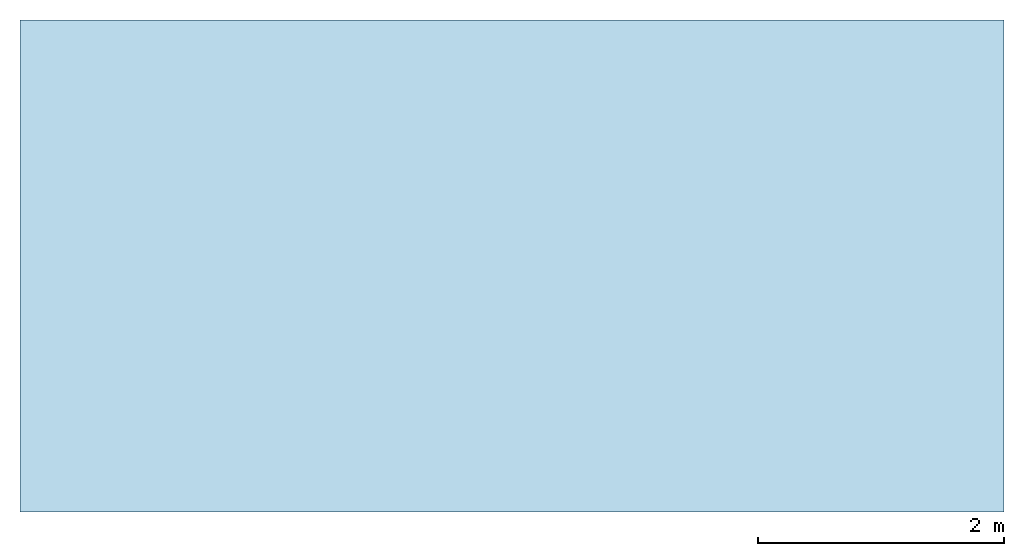
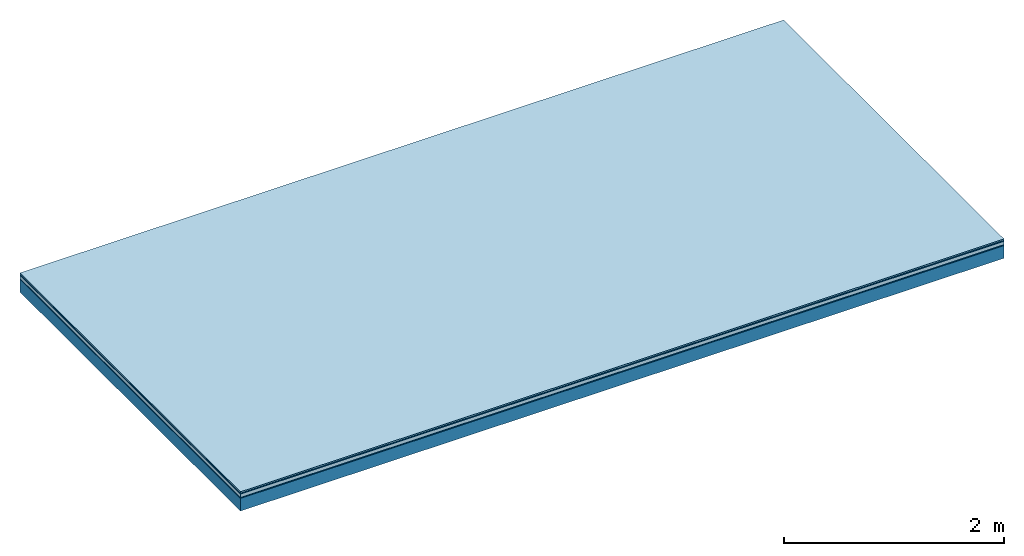
# One storey: 5 plates, 1 member, 1 element without a shape of its own.
"""IFC4 building model written with IfcOpenShell, lengths in metres."""

from ifc_helpers import new_model, si_unit, derived_unit, direction, frame, frame_2d, origin, origin_with_axes, place, context, project, spatial, rectangle, extrude, material, layer, layer_set, type_object, element, aggregate, save


model = new_model("IFC4")

# Units and contexts
plan_context = context("Plan", 3, precision=1e-05, world=origin(), true_north=direction((0.0, 1.0)))
model_context = context("Model", 3, precision=1e-05, world=origin(), true_north=direction((0.0, 1.0)))
ifc_project = project(units=[si_unit("LENGTHUNIT", "METRE"), derived_unit("SOUNDPRESSUREUNIT", [(si_unit("PRESSUREUNIT", "PASCAL", prefix="MICRO"), 0)]), si_unit("ENERGYUNIT", "JOULE", prefix="MEGA"), si_unit("MASSUNIT", "GRAM", prefix="KILO"), derived_unit("THERMALTRANSMITTANCEUNIT", [(si_unit("POWERUNIT", "WATT"), 1), (si_unit("AREAUNIT", "SQUARE_METRE"), -1), (si_unit("THERMODYNAMICTEMPERATUREUNIT", "KELVIN"), -1)]), derived_unit("AREADENSITYUNIT", [(si_unit("MASSUNIT", "GRAM", prefix="KILO"), 1), (si_unit("AREAUNIT", "SQUARE_METRE"), -1)]), derived_unit("USERDEFINED", [(si_unit("ENERGYUNIT", "JOULE", prefix="MEGA"), 1), (si_unit("AREAUNIT", "SQUARE_METRE"), -1)])], contexts=[plan_context, model_context])

# Site, building, storey
site = spatial("IfcSite", under=ifc_project)
building_placement = place(None, origin())
building = spatial("IfcBuilding", under=site, at=building_placement)
storey_placement = place(building_placement, origin())
storey = spatial("IfcBuildingStorey", under=building, at=storey_placement)

# Slab, member, plates
ifc_material_1 = material(Category="11.013")
ifc_layer_1 = layer(ifc_material_1, 0.015, Name="Flooring")
ifc_material_2 = material(Category="03.007")
ifc_layer_2 = layer(ifc_material_2, 0.01, Name="layer")
ifc_material_3 = material(Name="Floor heating system Therm38 standard", Category="03.007")
ifc_layer_3 = layer(ifc_material_3, 0.038, Name="On-material")
ifc_material_4 = material(Name="Wood fiber generic product", Category="10.009")
ifc_layer_4 = layer(ifc_material_4, 0.01, Name="Impact sound insulation")
ifc_material_5 = material(Name="protection", Category="09.007")
ifc_layer_5 = layer(ifc_material_5, 0.0005, Name="Sub-floor")
ifc_material_6 = material(Name="no composite action")
ifc_layer_6 = layer(ifc_material_6, 0.0, Name="Bond")
ifc_layer_7 = layer(None, 0.14, Name="Supporting structure")
ifc_layer_set = layer_set([ifc_layer_1, ifc_layer_2, ifc_layer_3, ifc_layer_4, ifc_layer_5, ifc_layer_6, ifc_layer_7])
slab_type = type_object("IfcSlabType", Name="A2034", PredefinedType="NOTDEFINED", material=ifc_layer_set)
slab_placement = place(None, frame((0.0, 0.0, 0.0), z_axis=(0.0, 0.0, -1.0), x_axis=(1.0, 0.0, 0.0)))
slab = element("IfcSlab", 1, at=slab_placement, inside=storey, type_object=slab_type, material=ifc_layer_set, Name="Slab #1")
ifc_material_7 = material(Name="Solid timber panel")
member_placement = place(slab_placement, origin())
member = element("IfcMember", 2, at=member_placement, material=ifc_material_7, Name="Supporting structure", context=plan_context, shape_type="SweptSolid", body=[
    extrude(rectangle(XDim=1.0, YDim=0.14, at=frame_2d((0.5, 0.07), x_axis=(1.0, 0.0))), frame((0.0, 4.0, 0.0735), z_axis=(0.0, -1.0, 0.0), x_axis=(1.0, 0.0, 0.0)), (0.0, 0.0, 1.0), 4.0),
    extrude(rectangle(XDim=1.0, YDim=0.14, at=frame_2d((0.5, 0.07), x_axis=(1.0, 0.0))), frame((1.0, 4.0, 0.0735), z_axis=(0.0, -1.0, 0.0), x_axis=(1.0, 0.0, 0.0)), (0.0, 0.0, 1.0), 4.0),
    extrude(rectangle(XDim=1.0, YDim=0.14, at=frame_2d((0.5, 0.07), x_axis=(1.0, 0.0))), frame((2.0, 4.0, 0.0735), z_axis=(0.0, -1.0, 0.0), x_axis=(1.0, 0.0, 0.0)), (0.0, 0.0, 1.0), 4.0),
    extrude(rectangle(XDim=1.0, YDim=0.14, at=frame_2d((0.5, 0.07), x_axis=(1.0, 0.0))), frame((3.0, 4.0, 0.0735), z_axis=(0.0, -1.0, 0.0), x_axis=(1.0, 0.0, 0.0)), (0.0, 0.0, 1.0), 4.0),
    extrude(rectangle(XDim=1.0, YDim=0.14, at=frame_2d((0.5, 0.07), x_axis=(1.0, 0.0))), frame((4.0, 4.0, 0.0735), z_axis=(0.0, -1.0, 0.0), x_axis=(1.0, 0.0, 0.0)), (0.0, 0.0, 1.0), 4.0),
    extrude(rectangle(XDim=1.0, YDim=0.14, at=frame_2d((0.5, 0.07), x_axis=(1.0, 0.0))), frame((5.0, 4.0, 0.0735), z_axis=(0.0, -1.0, 0.0), x_axis=(1.0, 0.0, 0.0)), (0.0, 0.0, 1.0), 4.0),
    extrude(rectangle(XDim=1.0, YDim=0.14, at=frame_2d((0.5, 0.07), x_axis=(1.0, 0.0))), frame((6.0, 4.0, 0.0735), z_axis=(0.0, -1.0, 0.0), x_axis=(1.0, 0.0, 0.0)), (0.0, 0.0, 1.0), 4.0),
    extrude(rectangle(XDim=1.0, YDim=0.14, at=frame_2d((0.5, 0.07), x_axis=(1.0, 0.0))), frame((7.0, 4.0, 0.0735), z_axis=(0.0, -1.0, 0.0), x_axis=(1.0, 0.0, 0.0)), (0.0, 0.0, 1.0), 4.0),
])
plate_1_placement = place(slab_placement, origin())
plate_1 = element("IfcPlate", 3, at=plate_1_placement, material=ifc_material_1, Name="Flooring", context=plan_context, shape_type="SweptSolid", body=[
    extrude(rectangle(XDim=8.0, YDim=4.0, at=frame_2d((4.0, 2.0), x_axis=(1.0, 0.0))), origin_with_axes(), (0.0, 0.0, 1.0), 0.015),
])
plate_2_placement = place(slab_placement, origin())
plate_2 = element("IfcPlate", 4, at=plate_2_placement, material=ifc_material_2, Name="layer", context=plan_context, shape_type="SweptSolid", body=[
    extrude(rectangle(XDim=8.0, YDim=4.0, at=frame_2d((4.0, 2.0), x_axis=(1.0, 0.0))), frame((0.0, 0.0, 0.015), z_axis=(0.0, 0.0, 1.0), x_axis=(1.0, 0.0, 0.0)), (0.0, 0.0, 1.0), 0.01),
])
plate_3_placement = place(slab_placement, origin())
plate_3 = element("IfcPlate", 5, at=plate_3_placement, material=ifc_material_3, Name="On-material", context=plan_context, shape_type="SweptSolid", body=[
    extrude(rectangle(XDim=8.0, YDim=4.0, at=frame_2d((4.0, 2.0), x_axis=(1.0, 0.0))), frame((0.0, 0.0, 0.025), z_axis=(0.0, 0.0, 1.0), x_axis=(1.0, 0.0, 0.0)), (0.0, 0.0, 1.0), 0.038),
])
plate_4_placement = place(slab_placement, origin())
plate_4 = element("IfcPlate", 6, at=plate_4_placement, material=ifc_material_4, Name="Impact sound insulation", context=plan_context, shape_type="SweptSolid", body=[
    extrude(rectangle(XDim=8.0, YDim=4.0, at=frame_2d((4.0, 2.0), x_axis=(1.0, 0.0))), frame((0.0, 0.0, 0.063), z_axis=(0.0, 0.0, 1.0), x_axis=(1.0, 0.0, 0.0)), (0.0, 0.0, 1.0), 0.01),
])
plate_5_placement = place(slab_placement, origin())
plate_5 = element("IfcPlate", 7, at=plate_5_placement, material=ifc_material_5, Name="Sub-floor", context=plan_context, shape_type="SweptSolid", body=[
    extrude(rectangle(XDim=8.0, YDim=4.0, at=frame_2d((4.0, 2.0), x_axis=(1.0, 0.0))), frame((0.0, 0.0, 0.073), z_axis=(0.0, 0.0, 1.0), x_axis=(1.0, 0.0, 0.0)), (0.0, 0.0, 1.0), 0.0005),
])
aggregate(slab, [plate_1, plate_2, plate_3, plate_4, plate_5, member])

save(model, "model.ifc")
